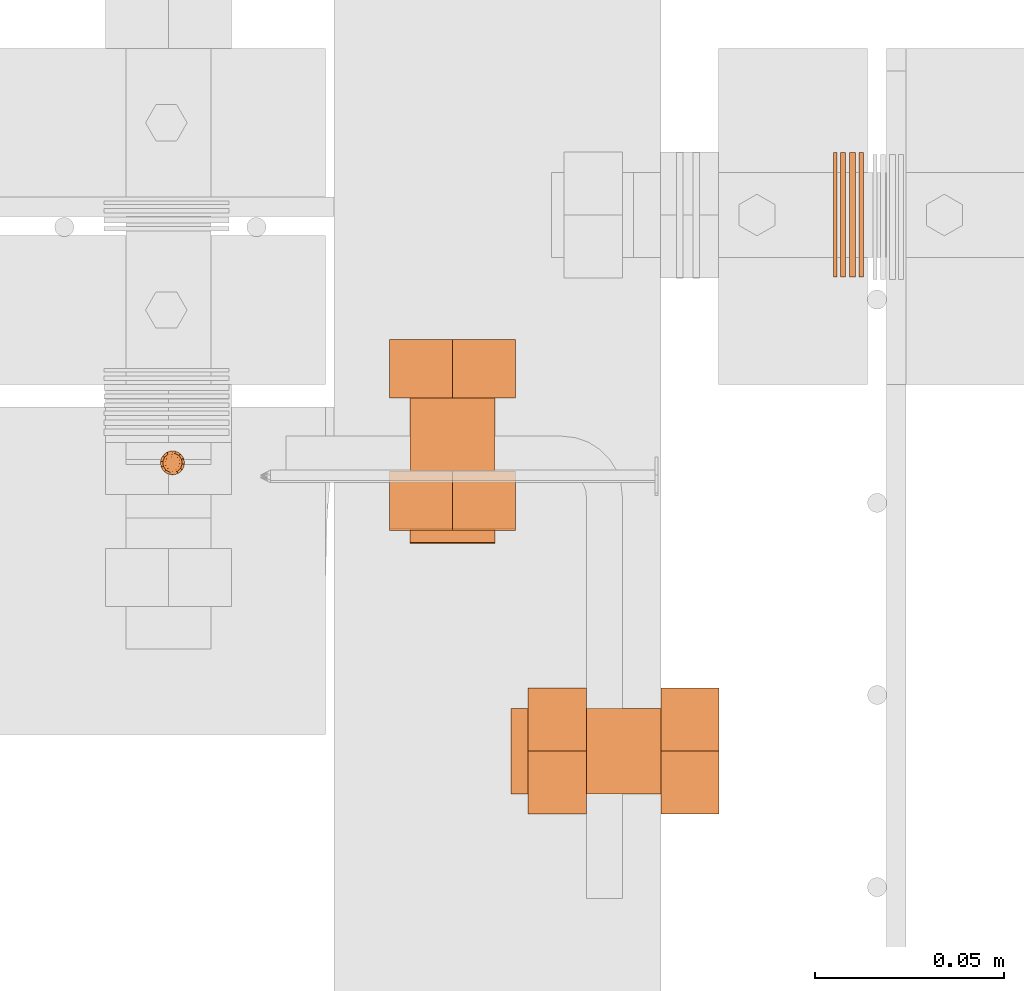
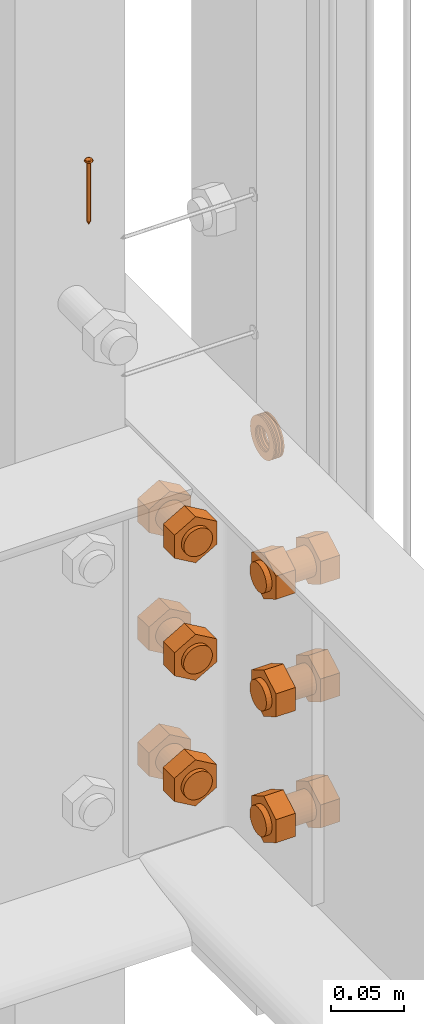
# One storey, part 37 of 44: 8 proxies.
"""IFC4 building model written with IfcOpenShell, lengths in feet."""

import ifcopenshell
import ifcopenshell.guid

model = None  # the IFC model being written
_history = None  # IfcOwnerHistory: only IFC2X3 demands one
_inside = {}  # id of a spatial element -> (the spatial element, [elements in it])
_under = {}  # id of a project, library or spatial element -> (it, [spatial elements below it])
_declared = {}  # id of a project -> (the project, [libraries it declares])
_typed = {}  # id of a type object -> (the type object, [elements of that type])
_made_of = {}  # id of a material, layer set ... -> (it, [elements and type objects made of it])


def new_model(schema):
    """Start an empty IFC model of exactly this schema.

    Asked for "IFC4X3", IfcOpenShell would pick the latest addendum, in which some entities
    have other attributes; the version numbers below select the first issue.
    IFC2X3 requires an IfcOwnerHistory on every rooted entity: one is made here for all.
    """
    global model, _history
    if schema == "IFC4X3":
        model = ifcopenshell.file(schema_version=(4, 3, 0, 0))
    else:
        model = ifcopenshell.file(schema=schema)
    _inside.clear()
    _under.clear()
    _declared.clear()
    _typed.clear()
    _made_of.clear()
    _history = None
    if model.schema == "IFC2X3":
        org = make("IfcOrganization", Name="unknown")
        user = make(
            "IfcPersonAndOrganization",
            ThePerson=make("IfcPerson", FamilyName="unknown"),
            TheOrganization=org,
        )
        app = make(
            "IfcApplication",
            ApplicationDeveloper=org,
            Version="unknown",
            ApplicationFullName="unknown",
            ApplicationIdentifier="unknown",
        )
        _history = make(
            "IfcOwnerHistory",
            OwningUser=user,
            OwningApplication=app,
            ChangeAction="ADDED",
            CreationDate=0,
        )
    return model


def make(cls, **values):
    """One entity of the class cls with the attributes given. An attribute that is None is left unset."""
    return model.create_entity(
        cls, **{name: value for name, value in values.items() if value is not None}
    )


def entity(cls, *values):
    """Any entity or typed value of the class cls, its attributes in the order of the schema. None: left unset."""
    e = model.create_entity(cls)
    for i, value in enumerate(values):
        if value is not None:
            e[i] = value
    return e


def rooted(cls, **values):
    """An entity with a GlobalId (a new one), such as an element, a storey or a relation."""
    return make(cls, GlobalId=ifcopenshell.guid.new(), OwnerHistory=_history, **values)


def si_unit(unit_type, name, prefix=None):
    """IfcSIUnit, for example si_unit("LENGTHUNIT", "METRE", prefix="MILLI")."""
    return make("IfcSIUnit", UnitType=unit_type, Prefix=prefix, Name=name)


def converted_unit(unit_type, name, factor, base, dimensions=None, offset=None):
    """IfcConversionBasedUnit, such as the inch: factor (a typed value) times the base unit."""
    return make(
        "IfcConversionBasedUnit"
        if offset is None
        else "IfcConversionBasedUnitWithOffset",
        ConversionOffset=offset,
        Dimensions=None
        if dimensions is None
        else entity("IfcDimensionalExponents", *dimensions),
        UnitType=unit_type,
        Name=name,
        ConversionFactor=make(
            "IfcMeasureWithUnit", ValueComponent=factor, UnitComponent=base
        ),
    )


def derived_unit(unit_type, elements):
    """IfcDerivedUnit: a product of units, each with its exponent."""
    return make(
        "IfcDerivedUnit",
        Elements=[
            make("IfcDerivedUnitElement", Unit=unit, Exponent=power)
            for unit, power in elements
        ],
        UnitType=unit_type,
    )


def assignment(units):
    """IfcUnitAssignment: the units of a project."""
    return None if units is None else make("IfcUnitAssignment", Units=units)


def point(xyz):
    """IfcCartesianPoint."""
    return None if xyz is None else make("IfcCartesianPoint", Coordinates=xyz)


def direction(xyz):
    """IfcDirection."""
    return None if xyz is None else make("IfcDirection", DirectionRatios=xyz)


def frame(location, z_axis=None, x_axis=None):
    """IfcAxis2Placement3D, a coordinate frame: its origin and axes. An axis left out is left unset."""
    return make(
        "IfcAxis2Placement3D",
        Location=point(location),
        Axis=direction(z_axis),
        RefDirection=direction(x_axis),
    )


def frame_2d(location, x_axis=None):
    """IfcAxis2Placement2D, a coordinate frame in the plane: its origin and x axis."""
    return make(
        "IfcAxis2Placement2D", Location=point(location), RefDirection=direction(x_axis)
    )


def origin():
    """The frame at (0, 0, 0) with its axes left unset."""
    return frame((0.0, 0.0, 0.0))


def origin_2d_with_axis():
    """The frame at (0, 0) in the plane with the x axis (1, 0) written out."""
    return frame_2d((0.0, 0.0), x_axis=(1.0, 0.0))


def place(relative_to, where):
    """IfcLocalPlacement: puts the frame where relative to a parent placement (None: the world)."""
    return make(
        "IfcLocalPlacement", PlacementRelTo=relative_to, RelativePlacement=where
    )


def context(
    kind, dimensions, precision=None, world=None, true_north=None, identifier=None
):
    """IfcGeometricRepresentationContext, for example the 3D "Model" context."""
    return make(
        "IfcGeometricRepresentationContext",
        ContextIdentifier=identifier,
        ContextType=kind,
        CoordinateSpaceDimension=dimensions,
        Precision=precision,
        WorldCoordinateSystem=world,
        TrueNorth=true_north,
    )


def subcontext(parent, identifier, kind, view, scale=None):
    """IfcGeometricRepresentationSubContext, for example "Body" below "Model"."""
    return make(
        "IfcGeometricRepresentationSubContext",
        ContextIdentifier=identifier,
        ContextType=kind,
        ParentContext=parent,
        TargetScale=scale,
        TargetView=view,
    )


def project(units=None, contexts=None):
    """IfcProject with its units and contexts."""
    return rooted(
        "IfcProject",
        Name="project",
        RepresentationContexts=contexts,
        UnitsInContext=assignment(units),
    )


def spatial(cls, under=None, at=None, **own):
    """A site, building, storey or space (cls), placed at a placement, below another one or the project."""
    s = rooted(cls, ObjectPlacement=at, **own)
    if under is not None:
        _under.setdefault(under.id(), (under, []))[1].append(s)
    return s


def polyline(points):
    """IfcPolyline through the points."""
    return make("IfcPolyline", Points=[point(p) for p in points])


def circle_curve(where, radius):
    """IfcCircle in the frame where."""
    return make("IfcCircle", Position=where, Radius=radius)


def parameter(value):
    """IfcParameterValue: where a trimmed curve begins or ends, as a parameter of its basis curve."""
    return model.create_entity("IfcParameterValue", value)


def trimmed(basis, trim1, trim2, sense, master):
    """IfcTrimmedCurve: the piece of a basis curve between two trims."""
    return make(
        "IfcTrimmedCurve",
        BasisCurve=basis,
        Trim1=trim1,
        Trim2=trim2,
        SenseAgreement=sense,
        MasterRepresentation=master,
    )


def segment(curve, same_sense, transition):
    """IfcCompositeCurveSegment."""
    return make(
        "IfcCompositeCurveSegment",
        Transition=transition,
        SameSense=same_sense,
        ParentCurve=curve,
    )


def composite_curve(segments, self_intersect=None):
    """IfcCompositeCurve: segments joined end to end."""
    return make("IfcCompositeCurve", Segments=segments, SelfIntersect=self_intersect)


def profile(cls, at=None, kind="AREA", **sizes):
    """A parametric profile (cls). Its sizes go by their IFC names, for example OverallWidth=200.0."""
    return make(cls, ProfileType=kind, Position=at, **sizes)


def circle(**sizes):
    """IfcCircleProfileDef."""
    return profile("IfcCircleProfileDef", **sizes)


def outline(outer, holes=None, kind="AREA"):
    """IfcArbitraryClosedProfileDef: a profile drawn as a closed curve; with holes, ...WithVoids."""
    if holes is None:
        return make("IfcArbitraryClosedProfileDef", ProfileType=kind, OuterCurve=outer)
    return make(
        "IfcArbitraryProfileDefWithVoids",
        ProfileType=kind,
        OuterCurve=outer,
        InnerCurves=holes,
    )


def extrude(swept, where, along, depth):
    """IfcExtrudedAreaSolid: the profile swept, set in the frame where, extruded along a direction by depth."""
    return make(
        "IfcExtrudedAreaSolid",
        SweptArea=swept,
        Position=where,
        ExtrudedDirection=direction(along),
        Depth=depth,
    )


def shape(context_of_items, identifier, shape_type, items):
    """IfcShapeRepresentation: the items that make up one representation, for example the "Body"."""
    return make(
        "IfcShapeRepresentation",
        ContextOfItems=context_of_items,
        RepresentationIdentifier=identifier,
        RepresentationType=shape_type,
        Items=items,
    )


def source(mapping_origin, context_of_items, identifier, shape_type, items):
    """IfcRepresentationMap: a shape defined once, which mapped items show again and again."""
    return make(
        "IfcRepresentationMap",
        MappingOrigin=mapping_origin,
        MappedRepresentation=shape(context_of_items, identifier, shape_type, items),
    )


def transform(
    local_origin,
    x_axis=None,
    y_axis=None,
    z_axis=None,
    scale=None,
    scale2=None,
    scale3=None,
    uniform=True,
):
    """IfcCartesianTransformationOperator3D, or its non-uniform kind. x_axis, y_axis, z_axis: its Axis1, 2, 3."""
    if uniform:
        return make(
            "IfcCartesianTransformationOperator3D",
            Axis1=direction(x_axis),
            Axis2=direction(y_axis),
            LocalOrigin=point(local_origin),
            Scale=scale,
            Axis3=direction(z_axis),
        )
    return make(
        "IfcCartesianTransformationOperator3DnonUniform",
        Axis1=direction(x_axis),
        Axis2=direction(y_axis),
        LocalOrigin=point(local_origin),
        Scale=scale,
        Axis3=direction(z_axis),
        Scale2=scale2,
        Scale3=scale3,
    )


def mapped(mapping_source, mapping_target):
    """IfcMappedItem: shows the shape of a source again, moved by a transform."""
    return make(
        "IfcMappedItem", MappingSource=mapping_source, MappingTarget=mapping_target
    )


def material(Name=None, Category=None):
    """IfcMaterial."""
    return make("IfcMaterial", Name=Name, Category=Category)


def made_of(thing, what):
    """Note that an element or type object is made of a material, layer set ...; save() writes the relation."""
    if what is not None:
        _made_of.setdefault(what.id(), (what, []))[1].append(thing)
    return thing


def type_object(cls, material=None, **own):
    """A type object (cls), such as IfcWallType, which elements share."""
    return made_of(rooted(cls, **own), material)


def type_shapes(of_type, sources):
    """Give a type object the sources (RepresentationMaps) that its elements show as mapped items."""
    of_type.RepresentationMaps = sources


def element(
    cls,
    number,
    at=None,
    inside=None,
    cuts=None,
    type_object=None,
    material=None,
    context=None,
    identifier="Body",
    shape_type=None,
    held_by="IfcProductDefinitionShape",
    body=None,
    shapes=None,
    **own,
):
    """One element of the class cls, such as IfcWall. Its Tag is "e" and its number.

    at: its placement. inside: the storey or other place that contains it. cuts: it is an
    opening in that element (IfcRelVoidsElement). A single representation is given by context,
    identifier, shape_type and body (its items); several are given by shapes. held_by: the class
    of the entity that holds the representations. save() writes the other relations.
    """
    e = rooted(cls, Tag="e%d" % number, ObjectPlacement=at, **own)
    if body is not None:
        shapes = [shape(context, identifier, shape_type, body)]
    if shapes is not None:
        e.Representation = make(held_by, Representations=shapes)
    if inside is not None:
        _inside.setdefault(inside.id(), (inside, []))[1].append(e)
    if cuts is not None:
        rooted(
            "IfcRelVoidsElement", RelatingBuildingElement=cuts, RelatedOpeningElement=e
        )
    if type_object is not None:
        _typed.setdefault(type_object.id(), (type_object, []))[1].append(e)
    return made_of(e, material)


def aggregate(whole, parts):
    """IfcRelAggregates: a whole, such as a stair, and the parts it consists of."""
    return rooted("IfcRelAggregates", RelatingObject=whole, RelatedObjects=parts)


def save(model, path):
    """Write the relations noted so far, then the file.

    IfcRelAggregates (storeys below a building ...), IfcRelContainedInSpatialStructure (elements
    in a storey), IfcRelDefinesByType, IfcRelAssociatesMaterial and IfcRelDeclares: one each for
    every whole, place, type object, material and project.
    """
    for whole, parts in _under.values():
        aggregate(whole, parts)
    for where, things in _inside.values():
        rooted(
            "IfcRelContainedInSpatialStructure",
            RelatedElements=things,
            RelatingStructure=where,
        )
    for kind, things in _typed.values():
        rooted("IfcRelDefinesByType", RelatedObjects=things, RelatingType=kind)
    for what, things in _made_of.values():
        rooted("IfcRelAssociatesMaterial", RelatedObjects=things, RelatingMaterial=what)
    for by, libraries in _declared.values():
        rooted("IfcRelDeclares", RelatingContext=by, RelatedDefinitions=libraries)
    model.write(path)


model = new_model("IFC4")

# Units and contexts
model_context = context("Model", 3, precision=0.0001, world=origin(), true_north=direction((6.12303176911189e-17, 1.0)))
body_context = subcontext(model_context, "Body", "Model", "MODEL_VIEW")
ifc_project = project(units=[converted_unit("LENGTHUNIT", "FOOT", entity("IfcRatioMeasure", 0.3048), si_unit("LENGTHUNIT", "METRE"), dimensions=[1, 0, 0, 0, 0, 0, 0]), converted_unit("AREAUNIT", "SQUARE FOOT", entity("IfcRatioMeasure", 0.09290304), si_unit("AREAUNIT", "SQUARE_METRE"), dimensions=[2, 0, 0, 0, 0, 0, 0]), converted_unit("VOLUMEUNIT", "CUBIC FOOT", entity("IfcRatioMeasure", 0.028316846592), si_unit("VOLUMEUNIT", "CUBIC_METRE"), dimensions=[3, 0, 0, 0, 0, 0, 0]), converted_unit("PLANEANGLEUNIT", "DEGREE", entity("IfcRatioMeasure", 0.0174532925199433), si_unit("PLANEANGLEUNIT", "RADIAN"), dimensions=[0, 0, 0, 0, 0, 0, 0]), si_unit("MASSUNIT", "GRAM", prefix="KILO"), derived_unit("MASSDENSITYUNIT", [(si_unit("MASSUNIT", "GRAM", prefix="KILO"), 1), (si_unit("LENGTHUNIT", "METRE"), -3)]), derived_unit("MOMENTOFINERTIAUNIT", [(si_unit("LENGTHUNIT", "METRE"), 4)]), si_unit("TIMEUNIT", "SECOND"), si_unit("FREQUENCYUNIT", "HERTZ"), si_unit("THERMODYNAMICTEMPERATUREUNIT", "DEGREE_CELSIUS"), derived_unit("THERMALTRANSMITTANCEUNIT", [(si_unit("MASSUNIT", "GRAM", prefix="KILO"), 1), (si_unit("THERMODYNAMICTEMPERATUREUNIT", "KELVIN"), -1), (si_unit("TIMEUNIT", "SECOND"), -3)]), derived_unit("VOLUMETRICFLOWRATEUNIT", [(si_unit("LENGTHUNIT", "METRE"), 3), (si_unit("TIMEUNIT", "SECOND"), -1)]), si_unit("ELECTRICCURRENTUNIT", "AMPERE"), si_unit("ELECTRICVOLTAGEUNIT", "VOLT"), si_unit("POWERUNIT", "WATT"), si_unit("FORCEUNIT", "NEWTON"), si_unit("ILLUMINANCEUNIT", "LUX"), si_unit("LUMINOUSFLUXUNIT", "LUMEN"), si_unit("LUMINOUSINTENSITYUNIT", "CANDELA"), derived_unit("USERDEFINED", [(si_unit("MASSUNIT", "GRAM", prefix="KILO"), -1), (si_unit("LENGTHUNIT", "METRE"), -2), (si_unit("TIMEUNIT", "SECOND"), 3), (si_unit("LUMINOUSFLUXUNIT", "LUMEN"), 1)]), derived_unit("LINEARVELOCITYUNIT", [(si_unit("LENGTHUNIT", "METRE"), 1), (si_unit("TIMEUNIT", "SECOND"), -1)]), si_unit("PRESSUREUNIT", "PASCAL"), derived_unit("USERDEFINED", [(si_unit("LENGTHUNIT", "METRE"), -2), (si_unit("MASSUNIT", "GRAM", prefix="KILO"), 1), (si_unit("TIMEUNIT", "SECOND"), -2)]), derived_unit("LINEARFORCEUNIT", [(si_unit("MASSUNIT", "GRAM", prefix="KILO"), 1), (si_unit("LENGTHUNIT", "METRE"), 1), (si_unit("TIMEUNIT", "SECOND"), -2), (si_unit("LENGTHUNIT", "METRE"), -1)]), derived_unit("PLANARFORCEUNIT", [(si_unit("MASSUNIT", "GRAM", prefix="KILO"), 1), (si_unit("LENGTHUNIT", "METRE"), 1), (si_unit("TIMEUNIT", "SECOND"), -2), (si_unit("LENGTHUNIT", "METRE"), -2)])], contexts=[model_context])

# Site, building, storey
site_placement = place(None, origin())
site = spatial("IfcSite", under=ifc_project, at=site_placement, CompositionType="ELEMENT")
building_placement = place(site_placement, origin())
building = spatial("IfcBuilding", under=site, at=building_placement, CompositionType="ELEMENT")
storey_placement = place(building_placement, origin())
storey = spatial("IfcBuildingStorey", under=building, at=storey_placement, CompositionType="ELEMENT", Elevation=0.0)

# Proxies
ifc_material_1 = material(Category="Materials")
building_element_proxy_type_1 = type_object("IfcBuildingElementProxyType", PredefinedType="NOTDEFINED", material=ifc_material_1)
cartesian_point_1 = entity("IfcCartesianPoint", [0.0, -0.00520833333344464, -0.164340723974429])
vertex_point_1 = entity("IfcVertexPoint", cartesian_point_1)
cartesian_point_2 = entity("IfcCartesianPoint", [0.0, 0.00520833333334609, -0.164340723974429])
vertex_point_2 = entity("IfcVertexPoint", cartesian_point_2)
cartesian_point_3 = entity("IfcCartesianPoint", [0.0, 0.0, -0.164340723974429])
ifc_direction_1 = entity("IfcDirection", [0.0, 0.0, 1.0])
ifc_direction_2 = entity("IfcDirection", [0.0, 1.0, 0.0])
edge_curve_1 = entity("IfcEdgeCurve", vertex_point_1, vertex_point_2, entity("IfcTrimmedCurve", entity("IfcCircle", entity("IfcAxis2Placement3D", cartesian_point_3, ifc_direction_1, ifc_direction_2), 0.00520833333339537), [cartesian_point_1], [cartesian_point_2], True, "CARTESIAN"), True)
vertex_point_3 = entity("IfcVertexPoint", cartesian_point_3)
ifc_direction_3 = entity("IfcDirection", [0.0, -1.0, 0.0])
edge_curve_2 = entity("IfcEdgeCurve", vertex_point_2, vertex_point_3, entity("IfcTrimmedCurve", entity("IfcLine", cartesian_point_2, entity("IfcVector", ifc_direction_3, 1.0)), [cartesian_point_2], [cartesian_point_3], True, "CARTESIAN"), True)
edge_curve_3 = entity("IfcEdgeCurve", vertex_point_3, vertex_point_1, entity("IfcTrimmedCurve", entity("IfcLine", cartesian_point_3, entity("IfcVector", ifc_direction_3, 1.0)), [cartesian_point_3], [cartesian_point_1], True, "CARTESIAN"), True)
edge_curve_4 = entity("IfcEdgeCurve", vertex_point_2, vertex_point_1, entity("IfcTrimmedCurve", entity("IfcCircle", entity("IfcAxis2Placement3D", cartesian_point_3, ifc_direction_1, ifc_direction_2), 0.00520833333339537), [cartesian_point_2], [cartesian_point_1], True, "CARTESIAN"), True)
cartesian_point_4 = entity("IfcCartesianPoint", [0.0, 0.0, -0.174757390640864])
vertex_point_4 = entity("IfcVertexPoint", cartesian_point_4)
edge_curve_5 = entity("IfcEdgeCurve", vertex_point_4, vertex_point_2, entity("IfcTrimmedCurve", entity("IfcLine", cartesian_point_4, entity("IfcVector", entity("IfcDirection", [0.0, 0.447213595512766, 0.894427190993512]), 1.0)), [cartesian_point_4], [cartesian_point_2], True, "CARTESIAN"), True)
edge_curve_6 = entity("IfcEdgeCurve", vertex_point_1, vertex_point_4, entity("IfcTrimmedCurve", entity("IfcLine", cartesian_point_1, entity("IfcVector", entity("IfcDirection", [0.0, 0.447213595512751, -0.894427190993519]), 1.0)), [cartesian_point_1], [cartesian_point_4], True, "CARTESIAN"), True)
cartesian_point_5 = entity("IfcCartesianPoint", [-0.0052083333333639, 0.0, -0.164340723974429])
cartesian_point_6 = entity("IfcCartesianPoint", [0.0, 0.0, -0.169209575232054])
ifc_direction_4 = entity("IfcDirection", [0.0, 0.0, -1.0])
cartesian_point_7 = entity("IfcCartesianPoint", [0.0, 0.0104166666665518, 0.0])
vertex_point_5 = entity("IfcVertexPoint", cartesian_point_7)
cartesian_point_8 = entity("IfcCartesianPoint", [0.0, -0.0104166666669052, 0.0])
vertex_point_6 = entity("IfcVertexPoint", cartesian_point_8)
cartesian_point_9 = entity("IfcCartesianPoint", [0.0, 0.0, 0.0])
ifc_direction_5 = entity("IfcDirection", [0.0, 0.0, -1.0])
ifc_direction_6 = entity("IfcDirection", [0.0, -1.0, 0.0])
edge_curve_7 = entity("IfcEdgeCurve", vertex_point_5, vertex_point_6, entity("IfcTrimmedCurve", entity("IfcCircle", entity("IfcAxis2Placement3D", cartesian_point_9, ifc_direction_5, ifc_direction_6), 0.0104166666667285), [cartesian_point_7], [cartesian_point_8], True, "CARTESIAN"), True)
vertex_point_7 = entity("IfcVertexPoint", cartesian_point_9)
ifc_direction_7 = entity("IfcDirection", [0.0, 1.0, 0.0])
edge_curve_8 = entity("IfcEdgeCurve", vertex_point_6, vertex_point_7, entity("IfcTrimmedCurve", entity("IfcLine", cartesian_point_8, entity("IfcVector", ifc_direction_7, 1.0)), [cartesian_point_8], [cartesian_point_9], True, "CARTESIAN"), True)
edge_curve_9 = entity("IfcEdgeCurve", vertex_point_7, vertex_point_5, entity("IfcTrimmedCurve", entity("IfcLine", cartesian_point_9, entity("IfcVector", ifc_direction_7, 1.0)), [cartesian_point_9], [cartesian_point_7], True, "CARTESIAN"), True)
edge_curve_10 = entity("IfcEdgeCurve", vertex_point_6, vertex_point_5, entity("IfcTrimmedCurve", entity("IfcCircle", entity("IfcAxis2Placement3D", cartesian_point_9, ifc_direction_5, ifc_direction_6), 0.0104166666667285), [cartesian_point_8], [cartesian_point_7], True, "CARTESIAN"), True)
cartesian_point_10 = entity("IfcCartesianPoint", [0.0, 0.0, 0.00520833333310164])
vertex_point_8 = entity("IfcVertexPoint", cartesian_point_10)
cartesian_point_11 = entity("IfcCartesianPoint", [0.0, -0.00520833333357187, 0.00520833333310168])
vertex_point_9 = entity("IfcVertexPoint", cartesian_point_11)
edge_curve_11 = entity("IfcEdgeCurve", vertex_point_8, vertex_point_9, entity("IfcTrimmedCurve", entity("IfcLine", cartesian_point_10, entity("IfcVector", ifc_direction_6, 1.0)), [cartesian_point_10], [cartesian_point_11], True, "CARTESIAN"), True)
cartesian_point_12 = entity("IfcCartesianPoint", [0.0, 0.00520833333321853, 0.00520833333310159])
vertex_point_10 = entity("IfcVertexPoint", cartesian_point_12)
ifc_direction_8 = entity("IfcDirection", [0.0, 0.0, 1.0])
edge_curve_12 = entity("IfcEdgeCurve", vertex_point_9, vertex_point_10, entity("IfcTrimmedCurve", entity("IfcCircle", entity("IfcAxis2Placement3D", cartesian_point_10, ifc_direction_8, ifc_direction_6), 0.00520833333339523), [cartesian_point_11], [cartesian_point_12], True, "CARTESIAN"), True)
edge_curve_13 = entity("IfcEdgeCurve", vertex_point_10, vertex_point_8, entity("IfcTrimmedCurve", entity("IfcLine", cartesian_point_12, entity("IfcVector", ifc_direction_6, 1.0)), [cartesian_point_12], [cartesian_point_10], True, "CARTESIAN"), True)
edge_curve_14 = entity("IfcEdgeCurve", vertex_point_10, vertex_point_9, entity("IfcTrimmedCurve", entity("IfcCircle", entity("IfcAxis2Placement3D", cartesian_point_10, ifc_direction_8, ifc_direction_6), 0.00520833333339523), [cartesian_point_12], [cartesian_point_11], True, "CARTESIAN"), True)
ifc_direction_9 = entity("IfcDirection", [1.0, 0.0, 0.0])
edge_curve_15 = entity("IfcEdgeCurve", vertex_point_9, vertex_point_6, entity("IfcTrimmedCurve", entity("IfcCircle", entity("IfcAxis2Placement3D", entity("IfcCartesianPoint", [0.0, -0.00520833333357193, 0.0]), ifc_direction_9, ifc_direction_6), 0.00520833333333331), [cartesian_point_11], [cartesian_point_8], True, "CARTESIAN"), True)
edge_curve_16 = entity("IfcEdgeCurve", vertex_point_5, vertex_point_10, entity("IfcTrimmedCurve", entity("IfcCircle", entity("IfcAxis2Placement3D", entity("IfcCartesianPoint", [0.0, 0.0052083333332185, 0.0]), ifc_direction_9, ifc_direction_7), 0.00520833333333331), [cartesian_point_7], [cartesian_point_12], True, "CARTESIAN"), True)
cartesian_point_13 = entity("IfcCartesianPoint", [0.00520833333332085, 0.0, 0.0])
cartesian_point_14 = entity("IfcCartesianPoint", [0.0104166666666542, 0.0, 0.0])
cartesian_point_15 = entity("IfcCartesianPoint", [0.0052083333333208, 0.0, 0.00520833333310163])
cartesian_point_16 = entity("IfcCartesianPoint", [0.0, -0.00520833333348769, 0.0])
vertex_point_11 = entity("IfcVertexPoint", cartesian_point_16)
cartesian_point_17 = entity("IfcCartesianPoint", [0.0, 0.00520833333317898, 0.0])
vertex_point_12 = entity("IfcVertexPoint", cartesian_point_17)
cartesian_point_18 = entity("IfcCartesianPoint", [0.0, 0.0, 0.0])
ifc_direction_10 = entity("IfcDirection", [0.0, 0.0, 1.0])
ifc_direction_11 = entity("IfcDirection", [0.0, 1.0, 0.0])
edge_curve_17 = entity("IfcEdgeCurve", vertex_point_11, vertex_point_12, entity("IfcTrimmedCurve", entity("IfcCircle", entity("IfcAxis2Placement3D", cartesian_point_18, ifc_direction_10, ifc_direction_11), 0.00520833333333333), [cartesian_point_16], [cartesian_point_17], True, "CARTESIAN"), True)
edge_curve_18 = entity("IfcEdgeCurve", vertex_point_12, vertex_point_11, entity("IfcTrimmedCurve", entity("IfcCircle", entity("IfcAxis2Placement3D", cartesian_point_18, ifc_direction_10, ifc_direction_11), 0.00520833333333333), [cartesian_point_17], [cartesian_point_16], True, "CARTESIAN"), True)
cartesian_point_19 = entity("IfcCartesianPoint", [0.0, -0.0052083333334891, -0.164340723974537])
vertex_point_13 = entity("IfcVertexPoint", cartesian_point_19)
cartesian_point_20 = entity("IfcCartesianPoint", [0.0, 0.00520833333317756, -0.164340723974537])
vertex_point_14 = entity("IfcVertexPoint", cartesian_point_20)
cartesian_point_21 = entity("IfcCartesianPoint", [0.0, 0.0, -0.164340723974537])
ifc_direction_12 = entity("IfcDirection", [0.0, 0.0, -1.0])
edge_curve_19 = entity("IfcEdgeCurve", vertex_point_13, vertex_point_14, entity("IfcTrimmedCurve", entity("IfcCircle", entity("IfcAxis2Placement3D", cartesian_point_21, ifc_direction_12, ifc_direction_11), 0.00520833333333333), [cartesian_point_19], [cartesian_point_20], True, "CARTESIAN"), True)
edge_curve_20 = entity("IfcEdgeCurve", vertex_point_14, vertex_point_13, entity("IfcTrimmedCurve", entity("IfcCircle", entity("IfcAxis2Placement3D", cartesian_point_21, ifc_direction_12, ifc_direction_11), 0.00520833333333333), [cartesian_point_20], [cartesian_point_19], True, "CARTESIAN"), True)
edge_curve_21 = entity("IfcEdgeCurve", vertex_point_11, vertex_point_13, entity("IfcTrimmedCurve", entity("IfcLine", cartesian_point_16, entity("IfcVector", ifc_direction_12, 1.0)), [cartesian_point_16], [cartesian_point_19], True, "CARTESIAN"), True)
edge_curve_22 = entity("IfcEdgeCurve", vertex_point_14, vertex_point_12, entity("IfcTrimmedCurve", entity("IfcLine", cartesian_point_17, entity("IfcVector", ifc_direction_10, 1.0)), [cartesian_point_20], [cartesian_point_17], True, "CARTESIAN"), True)
shared_shape_1 = source(origin(), body_context, "Body", "AdvancedBrep", [
    entity("IfcAdvancedBrep", entity("IfcClosedShell", [entity("IfcAdvancedFace", [entity("IfcFaceOuterBound", entity("IfcEdgeLoop", [entity("IfcOrientedEdge", None, None, edge_curve_1, True), entity("IfcOrientedEdge", None, None, edge_curve_2, True), entity("IfcOrientedEdge", None, None, edge_curve_3, True)]), True)], entity("IfcPlane", entity("IfcAxis2Placement3D", cartesian_point_3, ifc_direction_1, ifc_direction_2)), True), entity("IfcAdvancedFace", [entity("IfcFaceOuterBound", entity("IfcEdgeLoop", [entity("IfcOrientedEdge", None, None, edge_curve_4, True), entity("IfcOrientedEdge", None, None, edge_curve_3, False), entity("IfcOrientedEdge", None, None, edge_curve_2, False)]), True)], entity("IfcPlane", entity("IfcAxis2Placement3D", cartesian_point_3, ifc_direction_1, ifc_direction_2)), True), entity("IfcAdvancedFace", [entity("IfcFaceOuterBound", entity("IfcEdgeLoop", [entity("IfcOrientedEdge", None, None, edge_curve_5, True), entity("IfcOrientedEdge", None, None, edge_curve_1, False), entity("IfcOrientedEdge", None, None, edge_curve_6, True)]), True)], entity("IfcSurfaceOfRevolution", entity("IfcArbitraryOpenProfileDef", "CURVE", None, entity("IfcTrimmedCurve", entity("IfcLine", cartesian_point_4, entity("IfcVector", entity("IfcDirection", [0.447213595512749, 0.0, -0.894427190993521]), 1.0)), [cartesian_point_5], [cartesian_point_4], True, "CARTESIAN")), None, entity("IfcAxis1Placement", cartesian_point_6, ifc_direction_4)), True), entity("IfcAdvancedFace", [entity("IfcFaceOuterBound", entity("IfcEdgeLoop", [entity("IfcOrientedEdge", None, None, edge_curve_6, False), entity("IfcOrientedEdge", None, None, edge_curve_4, False), entity("IfcOrientedEdge", None, None, edge_curve_5, False)]), True)], entity("IfcSurfaceOfRevolution", entity("IfcArbitraryOpenProfileDef", "CURVE", None, entity("IfcTrimmedCurve", entity("IfcLine", cartesian_point_4, entity("IfcVector", entity("IfcDirection", [0.447213595512749, 0.0, -0.894427190993521]), 1.0)), [cartesian_point_5], [cartesian_point_4], True, "CARTESIAN")), None, entity("IfcAxis1Placement", cartesian_point_6, ifc_direction_4)), True)])),
    entity("IfcAdvancedBrep", entity("IfcClosedShell", [entity("IfcAdvancedFace", [entity("IfcFaceOuterBound", entity("IfcEdgeLoop", [entity("IfcOrientedEdge", None, None, edge_curve_7, True), entity("IfcOrientedEdge", None, None, edge_curve_8, True), entity("IfcOrientedEdge", None, None, edge_curve_9, True)]), True)], entity("IfcPlane", entity("IfcAxis2Placement3D", cartesian_point_9, ifc_direction_5, ifc_direction_6)), True), entity("IfcAdvancedFace", [entity("IfcFaceOuterBound", entity("IfcEdgeLoop", [entity("IfcOrientedEdge", None, None, edge_curve_10, True), entity("IfcOrientedEdge", None, None, edge_curve_9, False), entity("IfcOrientedEdge", None, None, edge_curve_8, False)]), True)], entity("IfcPlane", entity("IfcAxis2Placement3D", cartesian_point_9, ifc_direction_5, ifc_direction_6)), True), entity("IfcAdvancedFace", [entity("IfcFaceOuterBound", entity("IfcEdgeLoop", [entity("IfcOrientedEdge", None, None, edge_curve_11, True), entity("IfcOrientedEdge", None, None, edge_curve_12, True), entity("IfcOrientedEdge", None, None, edge_curve_13, True)]), True)], entity("IfcPlane", entity("IfcAxis2Placement3D", cartesian_point_10, ifc_direction_8, ifc_direction_6)), True), entity("IfcAdvancedFace", [entity("IfcFaceOuterBound", entity("IfcEdgeLoop", [entity("IfcOrientedEdge", None, None, edge_curve_13, False), entity("IfcOrientedEdge", None, None, edge_curve_14, True), entity("IfcOrientedEdge", None, None, edge_curve_11, False)]), True)], entity("IfcPlane", entity("IfcAxis2Placement3D", cartesian_point_10, ifc_direction_8, ifc_direction_6)), True), entity("IfcAdvancedFace", [entity("IfcFaceOuterBound", entity("IfcEdgeLoop", [entity("IfcOrientedEdge", None, None, edge_curve_12, False), entity("IfcOrientedEdge", None, None, edge_curve_15, True), entity("IfcOrientedEdge", None, None, edge_curve_7, False), entity("IfcOrientedEdge", None, None, edge_curve_16, True)]), True)], entity("IfcSurfaceOfRevolution", entity("IfcArbitraryOpenProfileDef", "CURVE", None, entity("IfcTrimmedCurve", entity("IfcCircle", entity("IfcAxis2Placement3D", cartesian_point_13, ifc_direction_6, ifc_direction_9), 0.00520833333333331), [cartesian_point_14], [cartesian_point_15], True, "CARTESIAN")), None, entity("IfcAxis1Placement", cartesian_point_10, ifc_direction_8)), True), entity("IfcAdvancedFace", [entity("IfcFaceOuterBound", entity("IfcEdgeLoop", [entity("IfcOrientedEdge", None, None, edge_curve_14, False), entity("IfcOrientedEdge", None, None, edge_curve_16, False), entity("IfcOrientedEdge", None, None, edge_curve_10, False), entity("IfcOrientedEdge", None, None, edge_curve_15, False)]), True)], entity("IfcSurfaceOfRevolution", entity("IfcArbitraryOpenProfileDef", "CURVE", None, entity("IfcTrimmedCurve", entity("IfcCircle", entity("IfcAxis2Placement3D", cartesian_point_13, ifc_direction_6, ifc_direction_9), 0.00520833333333331), [cartesian_point_14], [cartesian_point_15], True, "CARTESIAN")), None, entity("IfcAxis1Placement", cartesian_point_10, ifc_direction_8)), True)])),
    entity("IfcAdvancedBrep", entity("IfcClosedShell", [entity("IfcAdvancedFace", [entity("IfcFaceOuterBound", entity("IfcEdgeLoop", [entity("IfcOrientedEdge", None, None, edge_curve_17, True), entity("IfcOrientedEdge", None, None, edge_curve_18, True)]), True)], entity("IfcPlane", entity("IfcAxis2Placement3D", cartesian_point_17, ifc_direction_10, entity("IfcDirection", [-1.0, 0.0, 0.0]))), True), entity("IfcAdvancedFace", [entity("IfcFaceOuterBound", entity("IfcEdgeLoop", [entity("IfcOrientedEdge", None, None, edge_curve_19, True), entity("IfcOrientedEdge", None, None, edge_curve_20, True)]), True)], entity("IfcPlane", entity("IfcAxis2Placement3D", cartesian_point_20, ifc_direction_12, entity("IfcDirection", [1.0, 0.0, 0.0]))), True), entity("IfcAdvancedFace", [entity("IfcFaceOuterBound", entity("IfcEdgeLoop", [entity("IfcOrientedEdge", None, None, edge_curve_17, False), entity("IfcOrientedEdge", None, None, edge_curve_21, True), entity("IfcOrientedEdge", None, None, edge_curve_20, False), entity("IfcOrientedEdge", None, None, edge_curve_22, True)]), True)], entity("IfcCylindricalSurface", entity("IfcAxis2Placement3D", cartesian_point_21, ifc_direction_10, ifc_direction_11), 0.00520833333333333), True), entity("IfcAdvancedFace", [entity("IfcFaceOuterBound", entity("IfcEdgeLoop", [entity("IfcOrientedEdge", None, None, edge_curve_18, False), entity("IfcOrientedEdge", None, None, edge_curve_22, False), entity("IfcOrientedEdge", None, None, edge_curve_19, False), entity("IfcOrientedEdge", None, None, edge_curve_21, False)]), True)], entity("IfcCylindricalSurface", entity("IfcAxis2Placement3D", cartesian_point_21, ifc_direction_10, ifc_direction_11), 0.00520833333333333), True)])),
])
type_shapes(building_element_proxy_type_1, [shared_shape_1])
proxy_1_placement = place(storey_placement, frame((1493.86874166585, 4.68991881389409, 10.7226156988171)))
element("IfcBuildingElementProxy", 1, at=proxy_1_placement, inside=storey, type_object=building_element_proxy_type_1, material=ifc_material_1, PredefinedType="NOTDEFINED", context=body_context, shape_type="MappedRepresentation", body=[
    mapped(shared_shape_1, transform((0.0, 0.0, 0.0), scale=1.0)),
])
ifc_material_2 = material(Name="EXPOSED LAG BOLTS", Category="Materials")
building_element_proxy_type_2 = type_object("IfcBuildingElementProxyType", PredefinedType="NOTDEFINED", material=ifc_material_2)
shared_shape_2 = source(origin(), body_context, "Body", "SweptSolid", [
    extrude(outline(polyline([(-0.0315738428463097, -0.0546875000000126), (0.0315738428462861, -0.0546875000000126), (0.0631476856926272, 0.0), (0.0315738428463528, 0.0546874999999876), (-0.0315738428463294, 0.0546874999999873), (-0.0631476856926271, 0.0), (-0.0315738428463097, -0.0546875000000126)])), frame((0.0, 0.0, -0.115039062500389), z_axis=(0.0, 0.0, 1.0), x_axis=(0.866025403784438, -0.500000000000001, 0.0)), (0.0, 0.0, 1.0), 0.0504557291666658),
    extrude(outline(polyline([(-0.0315738428463175, -0.054687500000008), (0.0315738428463173, -0.054687500000008), (0.0631476856926152, 0.0), (0.0315738428462743, 0.0546875000000329), (-0.0315738428462739, 0.0546875000000332), (-0.0631476856926154, 0.0), (-0.0315738428463175, -0.054687500000008)])), frame((0.0, 0.0, 0.0), z_axis=(0.0, 0.0, 1.0), x_axis=(0.0, -1.0, 0.0)), (0.0, 0.0, 1.0), 0.0504557291666658),
    extrude(circle(Radius=0.0372721354166667, at=frame_2d((3.04388178754697e-18, -6.0214796149918e-17), x_axis=(1.0, 0.0))), frame((0.0, 0.0, -0.125499810688055), z_axis=(0.0, 0.0, 1.0), x_axis=(0.0, 1.0, 0.0)), (0.0, 0.0, 1.0), 0.125499810688048),
])
type_shapes(building_element_proxy_type_2, [shared_shape_2])
proxy_2_placement = place(storey_placement, frame((1494.1116771081, 4.74638587109973, 9.31485268691633), z_axis=(0.0, 1.0, 0.0), x_axis=(-1.0, 0.0, 0.0)))
element("IfcBuildingElementProxy", 2, at=proxy_2_placement, inside=storey, type_object=building_element_proxy_type_2, material=ifc_material_2, PredefinedType="NOTDEFINED", context=body_context, shape_type="MappedRepresentation", body=[
    mapped(shared_shape_2, transform((0.0, 0.0, 0.0), scale=1.0)),
])
building_element_proxy_type_3 = type_object("IfcBuildingElementProxyType", PredefinedType="NOTDEFINED", material=ifc_material_2)
shared_shape_3 = source(origin(), body_context, "Body", "SweptSolid", [
    extrude(outline(polyline([(-0.0315738428463097, -0.0546875000000126), (0.0315738428462861, -0.0546875000000126), (0.0631476856926272, 0.0), (0.0315738428463528, 0.0546874999999876), (-0.0315738428463294, 0.0546874999999873), (-0.0631476856926271, 0.0), (-0.0315738428463097, -0.0546875000000126)])), frame((0.0, 0.0, -0.115039062500381), z_axis=(0.0, 0.0, 1.0), x_axis=(0.866025403784438, -0.500000000000001, 0.0)), (0.0, 0.0, 1.0), 0.0504557291666658),
    extrude(outline(polyline([(-0.0315738428463175, -0.054687500000008), (0.0315738428463173, -0.054687500000008), (0.0631476856926152, 0.0), (0.0315738428462743, 0.0546875000000329), (-0.0315738428462739, 0.0546875000000332), (-0.0631476856926154, 0.0), (-0.0315738428463175, -0.054687500000008)])), frame((0.0, 0.0, 0.0), z_axis=(0.0, 0.0, 1.0), x_axis=(0.0, -1.0, 0.0)), (0.0, 0.0, 1.0), 0.0504557291666658),
    extrude(circle(Radius=0.0372721354166667, at=frame_2d((1.03281497458998e-18, -6.0214796149918e-17), x_axis=(1.0, 0.0))), frame((0.0, 0.0, -0.129761278938013), z_axis=(0.0, 0.0, 1.0), x_axis=(0.0, 1.0, 0.0)), (0.0, 0.0, 1.0), 0.129761278938007),
])
type_shapes(building_element_proxy_type_3, [shared_shape_3])
for number, where, z_axis, x_axis in (
    (3, (1494.29228937919, 4.43984811174109, 9.30968984419157), (1.0, 0.0, 0.0), (0.0, 1.0, 0.0)),
    (4, (1494.29228937919, 4.43984811174109, 9.63131738274977), (1.0, 0.0, 0.0), (0.0, 1.0, 0.0)),
    (5, (1494.29228937919, 4.43984811174109, 8.96543744350564), (1.0, 0.0, 0.0), (0.0, 1.0, 0.0)),
):
    element("IfcBuildingElementProxy", number, at=place(storey_placement, frame(where, z_axis=z_axis, x_axis=x_axis)), inside=storey, type_object=building_element_proxy_type_3, material=ifc_material_2, PredefinedType="NOTDEFINED", context=body_context, shape_type="MappedRepresentation", body=[
        mapped(shared_shape_3, transform((0.0, 0.0, 0.0), scale=1.0)),
    ])
building_element_proxy_type_4 = type_object("IfcBuildingElementProxyType", PredefinedType="NOTDEFINED", material=ifc_material_2)
shared_shape_4 = source(origin(), body_context, "Body", "SweptSolid", [
    extrude(outline(polyline([(-0.0315738428463097, -0.0546875000000126), (0.0315738428462861, -0.0546875000000126), (0.0631476856926272, 0.0), (0.0315738428463528, 0.0546874999999876), (-0.0315738428463294, 0.0546874999999873), (-0.0631476856926271, 0.0), (-0.0315738428463097, -0.0546875000000126)])), frame((0.0, 0.0, -0.115039062500392), z_axis=(0.0, 0.0, 1.0), x_axis=(0.866025403784438, -0.500000000000001, 0.0)), (0.0, 0.0, 1.0), 0.0504557291666658),
    extrude(outline(polyline([(-0.0315738428463175, -0.054687500000008), (0.0315738428463173, -0.054687500000008), (0.0631476856926152, 0.0), (0.0315738428462743, 0.0546875000000329), (-0.0315738428462739, 0.0546875000000332), (-0.0631476856926154, 0.0), (-0.0315738428463175, -0.054687500000008)])), frame((0.0, 0.0, 0.0), z_axis=(0.0, 0.0, 1.0), x_axis=(0.0, -1.0, 0.0)), (0.0, 0.0, 1.0), 0.0504557291666658),
    extrude(circle(Radius=0.0372721354166667, at=frame_2d((1.57062027830795e-18, -6.0214796149918e-17), x_axis=(1.0, 0.0))), frame((0.0, 0.0, -0.126476451728853), z_axis=(0.0, 0.0, 1.0), x_axis=(0.0, 1.0, 0.0)), (0.0, 0.0, 1.0), 0.126476451728847),
])
type_shapes(building_element_proxy_type_4, [shared_shape_4])
proxy_3_placement = place(storey_placement, frame((1494.1116771081, 4.74638587109974, 9.63648022547453), z_axis=(0.0, 1.0, 0.0), x_axis=(-1.0, 0.0, 0.0)))
element("IfcBuildingElementProxy", 6, at=proxy_3_placement, inside=storey, type_object=building_element_proxy_type_4, material=ifc_material_2, PredefinedType="NOTDEFINED", context=body_context, shape_type="MappedRepresentation", body=[
    mapped(shared_shape_4, transform((0.0, 0.0, 0.0), scale=1.0)),
])
building_element_proxy_type_5 = type_object("IfcBuildingElementProxyType", PredefinedType="NOTDEFINED", material=ifc_material_2)
shared_shape_5 = source(origin(), body_context, "Body", "SweptSolid", [
    extrude(outline(polyline([(-0.0315738428463097, -0.0546875000000126), (0.0315738428462861, -0.0546875000000126), (0.0631476856926272, 0.0), (0.0315738428463528, 0.0546874999999876), (-0.0315738428463294, 0.0546874999999873), (-0.0631476856926271, 0.0), (-0.0315738428463097, -0.0546875000000126)])), frame((0.0, 0.0, -0.113872432705866), z_axis=(0.0, 0.0, 1.0), x_axis=(0.866025403784438, -0.500000000000001, 0.0)), (0.0, 0.0, 1.0), 0.0504557291666658),
    extrude(outline(polyline([(-0.0315738428463175, -0.054687500000008), (0.0315738428463173, -0.054687500000008), (0.0631476856926152, 0.0), (0.0315738428462743, 0.0546875000000329), (-0.0315738428462739, 0.0546875000000332), (-0.0631476856926154, 0.0), (-0.0315738428463175, -0.054687500000008)])), frame((0.0, 0.0, 0.0), z_axis=(0.0, 0.0, 1.0), x_axis=(0.0, -1.0, 0.0)), (0.0, 0.0, 1.0), 0.0504557291666658),
    extrude(circle(Radius=0.0372721354166667, at=frame_2d((3.0438817875977e-18, -6.0214796149918e-17), x_axis=(1.0, 0.0))), frame((0.0, 0.0, -0.125499810688049), z_axis=(0.0, 0.0, 1.0), x_axis=(0.0, 1.0, 0.0)), (0.0, 0.0, 1.0), 0.125499810688043),
])
type_shapes(building_element_proxy_type_5, [shared_shape_5])
proxy_4_placement = place(storey_placement, frame((1494.1116771081, 4.74638587109974, 8.9706002862304), z_axis=(0.0, 1.0, 0.0), x_axis=(-1.0, 0.0, 0.0)))
element("IfcBuildingElementProxy", 7, at=proxy_4_placement, inside=storey, type_object=building_element_proxy_type_5, material=ifc_material_2, PredefinedType="NOTDEFINED", context=body_context, shape_type="MappedRepresentation", body=[
    mapped(shared_shape_5, transform((0.0, 0.0, 0.0), scale=1.0)),
])
ifc_material_3 = material(Name="(2) GALV. (FOR DRAINAGE)", Category="Materials")
building_element_proxy_type_6 = type_object("IfcBuildingElementProxyType", Name="WASHER193:WASHER", PredefinedType="NOTDEFINED", material=ifc_material_3)
shared_shape_6 = source(origin(), body_context, "Body", "SweptSolid", [
    extrude(outline(composite_curve([segment(trimmed(circle_curve(origin_2d_with_axis(), 0.054126587736544), [parameter(360.0)], [parameter(180.0)], True, "PARAMETER"), True, "CONTINUOUS"), segment(trimmed(circle_curve(origin_2d_with_axis(), 0.054126587736544), [parameter(180.0)], [parameter(360.0)], True, "PARAMETER"), True, "CONTINUOUS")], self_intersect=False), holes=[composite_curve([segment(trimmed(circle_curve(frame_2d((0.0, 0.00204962727015712), x_axis=(1.0, 0.0)), 0.031438579453031), [parameter(180.0)], [parameter(360.0)], True, "PARAMETER"), False, "CONTINUOUS"), segment(trimmed(circle_curve(frame_2d((0.0, 0.00204962727015712), x_axis=(1.0, 0.0)), 0.031438579453031), [parameter(360.0)], [parameter(180.0)], True, "PARAMETER"), False, "CONTINUOUS")], self_intersect=False)]), frame((0.0, 0.0593604205315437, 0.0593604205315437), z_axis=(1.0, 0.0, 0.0), x_axis=(0.0, -1.0, 0.0)), (0.0, 0.0, 1.0), 0.00332179672204802),
    extrude(outline(composite_curve([segment(trimmed(circle_curve(origin_2d_with_axis(), 0.054126587736544), [parameter(180.0)], [parameter(360.0)], True, "PARAMETER"), True, "CONTINUOUS"), segment(trimmed(circle_curve(origin_2d_with_axis(), 0.054126587736544), [parameter(360.0)], [parameter(180.0)], True, "PARAMETER"), True, "CONTINUOUS")], self_intersect=False), holes=[composite_curve([segment(trimmed(circle_curve(frame_2d((0.0, 0.00204962727015712), x_axis=(1.0, 0.0)), 0.031438579453031), [parameter(360.0)], [parameter(180.0)], True, "PARAMETER"), False, "CONTINUOUS"), segment(trimmed(circle_curve(frame_2d((0.0, 0.00204962727015712), x_axis=(1.0, 0.0)), 0.031438579453031), [parameter(180.0)], [parameter(360.0)], True, "PARAMETER"), False, "CONTINUOUS")], self_intersect=False)]), frame((0.0220636819910851, 0.0593604205315437, 0.0593604205315437), z_axis=(1.0, 0.0, 0.0), x_axis=(0.0, -1.0, 0.0)), (0.0, 0.0, 1.0), 0.00404999031002262),
    extrude(outline(composite_curve([segment(trimmed(circle_curve(origin_2d_with_axis(), 0.054126587736544), [parameter(180.0)], [parameter(360.0)], True, "PARAMETER"), True, "CONTINUOUS"), segment(trimmed(circle_curve(origin_2d_with_axis(), 0.054126587736544), [parameter(360.0)], [parameter(180.0)], True, "PARAMETER"), True, "CONTINUOUS")], self_intersect=False), holes=[composite_curve([segment(trimmed(circle_curve(frame_2d((0.0, 0.00204962727015712), x_axis=(1.0, 0.0)), 0.031438579453031), [parameter(360.0)], [parameter(180.0)], True, "PARAMETER"), False, "CONTINUOUS"), segment(trimmed(circle_curve(frame_2d((0.0, 0.00204962727015712), x_axis=(1.0, 0.0)), 0.031438579453031), [parameter(180.0)], [parameter(360.0)], True, "PARAMETER"), False, "CONTINUOUS")], self_intersect=False)]), frame((0.00642093526334975, 0.0593604205315437, 0.0593604205315437), z_axis=(1.0, 0.0, 0.0), x_axis=(0.0, -1.0, 0.0)), (0.0, 0.0, 1.0), 0.00412198282083409),
    extrude(outline(composite_curve([segment(trimmed(circle_curve(origin_2d_with_axis(), 0.054126587736544), [parameter(180.0)], [parameter(360.0)], True, "PARAMETER"), True, "CONTINUOUS"), segment(trimmed(circle_curve(origin_2d_with_axis(), 0.054126587736544), [parameter(360.0)], [parameter(180.0)], True, "PARAMETER"), True, "CONTINUOUS")], self_intersect=False), holes=[composite_curve([segment(trimmed(circle_curve(frame_2d((0.0, 0.00204962727015712), x_axis=(1.0, 0.0)), 0.031438579453031), [parameter(360.0)], [parameter(180.0)], True, "PARAMETER"), False, "CONTINUOUS"), segment(trimmed(circle_curve(frame_2d((0.0, 0.00204962727015712), x_axis=(1.0, 0.0)), 0.031438579453031), [parameter(180.0)], [parameter(360.0)], True, "PARAMETER"), False, "CONTINUOUS")], self_intersect=False)]), frame((0.0141095597130061, 0.0593604205315437, 0.0593604205315437), z_axis=(1.0, 0.0, 0.0), x_axis=(0.0, -1.0, 0.0)), (0.0, 0.0, 1.0), 0.0051228935196832),
])
type_shapes(building_element_proxy_type_6, [shared_shape_6])
proxy_5_placement = place(storey_placement, frame((1494.4419554602, 4.84578055921961, 9.57411707518479)))
element("IfcBuildingElementProxy", 8, at=proxy_5_placement, inside=storey, type_object=building_element_proxy_type_6, material=ifc_material_3, Name="WASHER193:WASHER", ObjectType="WASHER193:WASHER", PredefinedType="NOTDEFINED", context=body_context, shape_type="MappedRepresentation", body=[
    mapped(shared_shape_6, transform((0.0, 0.0, 0.0), scale=1.0)),
])

save(model, "model.ifc")
